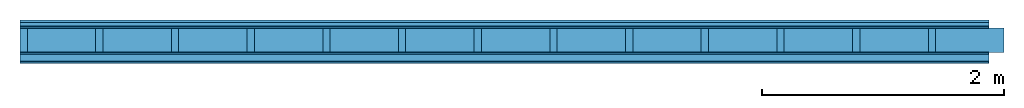
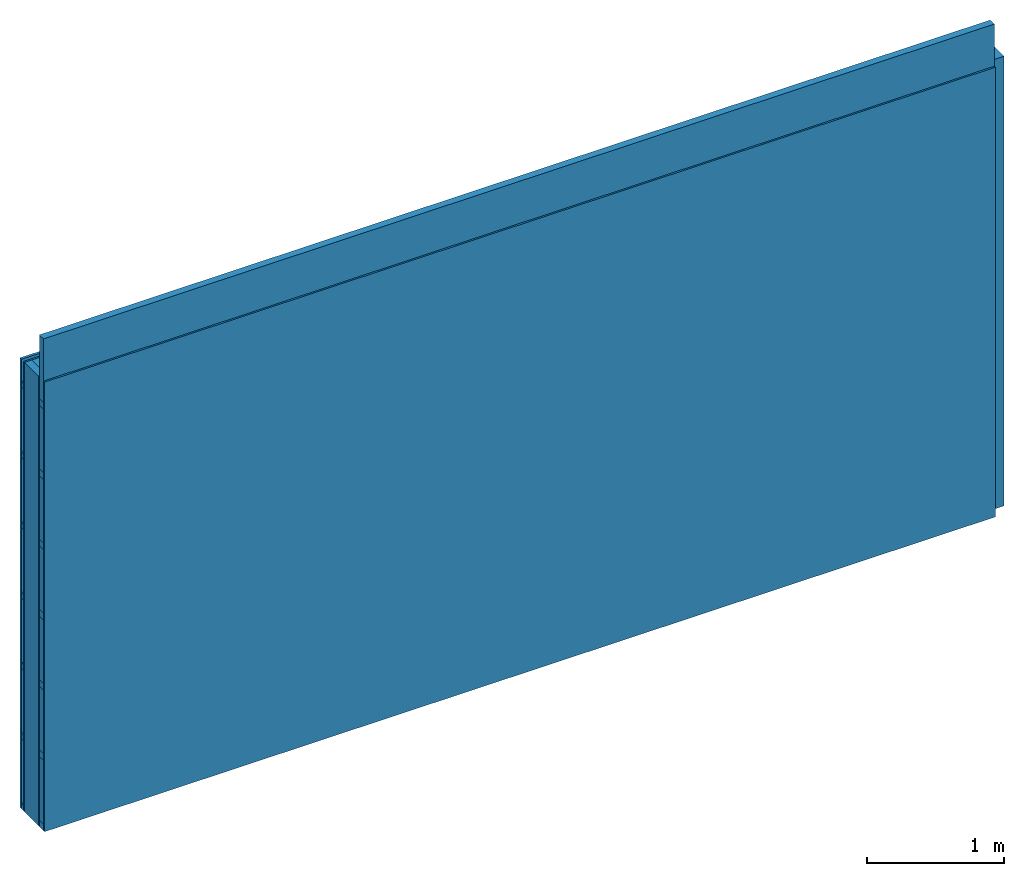
# One storey: 5 members, 4 plates, 1 element without a shape of its own.
"""IFC4 building model written with IfcOpenShell, lengths in metres."""

import ifcopenshell
import ifcopenshell.guid

model = None  # the IFC model being written
_history = None  # IfcOwnerHistory: only IFC2X3 demands one
_inside = {}  # id of a spatial element -> (the spatial element, [elements in it])
_under = {}  # id of a project, library or spatial element -> (it, [spatial elements below it])
_declared = {}  # id of a project -> (the project, [libraries it declares])
_typed = {}  # id of a type object -> (the type object, [elements of that type])
_made_of = {}  # id of a material, layer set ... -> (it, [elements and type objects made of it])


def new_model(schema):
    """Start an empty IFC model of exactly this schema.

    Asked for "IFC4X3", IfcOpenShell would pick the latest addendum, in which some entities
    have other attributes; the version numbers below select the first issue.
    IFC2X3 requires an IfcOwnerHistory on every rooted entity: one is made here for all.
    """
    global model, _history
    if schema == "IFC4X3":
        model = ifcopenshell.file(schema_version=(4, 3, 0, 0))
    else:
        model = ifcopenshell.file(schema=schema)
    _inside.clear()
    _under.clear()
    _declared.clear()
    _typed.clear()
    _made_of.clear()
    _history = None
    if model.schema == "IFC2X3":
        org = make("IfcOrganization", Name="unknown")
        user = make(
            "IfcPersonAndOrganization",
            ThePerson=make("IfcPerson", FamilyName="unknown"),
            TheOrganization=org,
        )
        app = make(
            "IfcApplication",
            ApplicationDeveloper=org,
            Version="unknown",
            ApplicationFullName="unknown",
            ApplicationIdentifier="unknown",
        )
        _history = make(
            "IfcOwnerHistory",
            OwningUser=user,
            OwningApplication=app,
            ChangeAction="ADDED",
            CreationDate=0,
        )
    return model


def make(cls, **values):
    """One entity of the class cls with the attributes given. An attribute that is None is left unset."""
    return model.create_entity(
        cls, **{name: value for name, value in values.items() if value is not None}
    )


def rooted(cls, **values):
    """An entity with a GlobalId (a new one), such as an element, a storey or a relation."""
    return make(cls, GlobalId=ifcopenshell.guid.new(), OwnerHistory=_history, **values)


def si_unit(unit_type, name, prefix=None):
    """IfcSIUnit, for example si_unit("LENGTHUNIT", "METRE", prefix="MILLI")."""
    return make("IfcSIUnit", UnitType=unit_type, Prefix=prefix, Name=name)


def derived_unit(unit_type, elements):
    """IfcDerivedUnit: a product of units, each with its exponent."""
    return make(
        "IfcDerivedUnit",
        Elements=[
            make("IfcDerivedUnitElement", Unit=unit, Exponent=power)
            for unit, power in elements
        ],
        UnitType=unit_type,
    )


def assignment(units):
    """IfcUnitAssignment: the units of a project."""
    return None if units is None else make("IfcUnitAssignment", Units=units)


def point(xyz):
    """IfcCartesianPoint."""
    return None if xyz is None else make("IfcCartesianPoint", Coordinates=xyz)


def direction(xyz):
    """IfcDirection."""
    return None if xyz is None else make("IfcDirection", DirectionRatios=xyz)


def frame(location, z_axis=None, x_axis=None):
    """IfcAxis2Placement3D, a coordinate frame: its origin and axes. An axis left out is left unset."""
    return make(
        "IfcAxis2Placement3D",
        Location=point(location),
        Axis=direction(z_axis),
        RefDirection=direction(x_axis),
    )


def frame_2d(location, x_axis=None):
    """IfcAxis2Placement2D, a coordinate frame in the plane: its origin and x axis."""
    return make(
        "IfcAxis2Placement2D", Location=point(location), RefDirection=direction(x_axis)
    )


def origin():
    """The frame at (0, 0, 0) with its axes left unset."""
    return frame((0.0, 0.0, 0.0))


def origin_with_axes():
    """The frame at (0, 0, 0) with the z axis (0, 0, 1) and the x axis (1, 0, 0) written out."""
    return frame((0.0, 0.0, 0.0), z_axis=(0.0, 0.0, 1.0), x_axis=(1.0, 0.0, 0.0))


def place(relative_to, where):
    """IfcLocalPlacement: puts the frame where relative to a parent placement (None: the world)."""
    return make(
        "IfcLocalPlacement", PlacementRelTo=relative_to, RelativePlacement=where
    )


def context(
    kind, dimensions, precision=None, world=None, true_north=None, identifier=None
):
    """IfcGeometricRepresentationContext, for example the 3D "Model" context."""
    return make(
        "IfcGeometricRepresentationContext",
        ContextIdentifier=identifier,
        ContextType=kind,
        CoordinateSpaceDimension=dimensions,
        Precision=precision,
        WorldCoordinateSystem=world,
        TrueNorth=true_north,
    )


def project(units=None, contexts=None):
    """IfcProject with its units and contexts."""
    return rooted(
        "IfcProject",
        Name="project",
        RepresentationContexts=contexts,
        UnitsInContext=assignment(units),
    )


def spatial(cls, under=None, at=None, **own):
    """A site, building, storey or space (cls), placed at a placement, below another one or the project."""
    s = rooted(cls, ObjectPlacement=at, **own)
    if under is not None:
        _under.setdefault(under.id(), (under, []))[1].append(s)
    return s


def profile(cls, at=None, kind="AREA", **sizes):
    """A parametric profile (cls). Its sizes go by their IFC names, for example OverallWidth=200.0."""
    return make(cls, ProfileType=kind, Position=at, **sizes)


def rectangle(**sizes):
    """IfcRectangleProfileDef."""
    return profile("IfcRectangleProfileDef", **sizes)


def extrude(swept, where, along, depth):
    """IfcExtrudedAreaSolid: the profile swept, set in the frame where, extruded along a direction by depth."""
    return make(
        "IfcExtrudedAreaSolid",
        SweptArea=swept,
        Position=where,
        ExtrudedDirection=direction(along),
        Depth=depth,
    )


def shape(context_of_items, identifier, shape_type, items):
    """IfcShapeRepresentation: the items that make up one representation, for example the "Body"."""
    return make(
        "IfcShapeRepresentation",
        ContextOfItems=context_of_items,
        RepresentationIdentifier=identifier,
        RepresentationType=shape_type,
        Items=items,
    )


def material(Name=None, Category=None):
    """IfcMaterial."""
    return make("IfcMaterial", Name=Name, Category=Category)


def layer(
    of_material, thickness, ventilated=None, Name=None, Category=None, Priority=None
):
    """IfcMaterialLayer: one layer of a wall or slab, of a material (None: an air gap)."""
    return make(
        "IfcMaterialLayer",
        Material=of_material,
        LayerThickness=thickness,
        IsVentilated=ventilated,
        Name=Name,
        Category=Category,
        Priority=Priority,
    )


def layer_set(layers, Name=None):
    """IfcMaterialLayerSet."""
    return make("IfcMaterialLayerSet", MaterialLayers=layers, LayerSetName=Name)


def made_of(thing, what):
    """Note that an element or type object is made of a material, layer set ...; save() writes the relation."""
    if what is not None:
        _made_of.setdefault(what.id(), (what, []))[1].append(thing)
    return thing


def type_object(cls, material=None, **own):
    """A type object (cls), such as IfcWallType, which elements share."""
    return made_of(rooted(cls, **own), material)


def element(
    cls,
    number,
    at=None,
    inside=None,
    cuts=None,
    type_object=None,
    material=None,
    context=None,
    identifier="Body",
    shape_type=None,
    held_by="IfcProductDefinitionShape",
    body=None,
    shapes=None,
    **own,
):
    """One element of the class cls, such as IfcWall. Its Tag is "e" and its number.

    at: its placement. inside: the storey or other place that contains it. cuts: it is an
    opening in that element (IfcRelVoidsElement). A single representation is given by context,
    identifier, shape_type and body (its items); several are given by shapes. held_by: the class
    of the entity that holds the representations. save() writes the other relations.
    """
    e = rooted(cls, Tag="e%d" % number, ObjectPlacement=at, **own)
    if body is not None:
        shapes = [shape(context, identifier, shape_type, body)]
    if shapes is not None:
        e.Representation = make(held_by, Representations=shapes)
    if inside is not None:
        _inside.setdefault(inside.id(), (inside, []))[1].append(e)
    if cuts is not None:
        rooted(
            "IfcRelVoidsElement", RelatingBuildingElement=cuts, RelatedOpeningElement=e
        )
    if type_object is not None:
        _typed.setdefault(type_object.id(), (type_object, []))[1].append(e)
    return made_of(e, material)


def aggregate(whole, parts):
    """IfcRelAggregates: a whole, such as a stair, and the parts it consists of."""
    return rooted("IfcRelAggregates", RelatingObject=whole, RelatedObjects=parts)


def save(model, path):
    """Write the relations noted so far, then the file.

    IfcRelAggregates (storeys below a building ...), IfcRelContainedInSpatialStructure (elements
    in a storey), IfcRelDefinesByType, IfcRelAssociatesMaterial and IfcRelDeclares: one each for
    every whole, place, type object, material and project.
    """
    for whole, parts in _under.values():
        aggregate(whole, parts)
    for where, things in _inside.values():
        rooted(
            "IfcRelContainedInSpatialStructure",
            RelatedElements=things,
            RelatingStructure=where,
        )
    for kind, things in _typed.values():
        rooted("IfcRelDefinesByType", RelatedObjects=things, RelatingType=kind)
    for what, things in _made_of.values():
        rooted("IfcRelAssociatesMaterial", RelatedObjects=things, RelatingMaterial=what)
    for by, libraries in _declared.values():
        rooted("IfcRelDeclares", RelatingContext=by, RelatedDefinitions=libraries)
    model.write(path)


model = new_model("IFC4")

# Units and contexts
plan_context = context("Plan", 3, precision=1e-05, world=origin(), true_north=direction((0.0, 1.0)))
model_context = context("Model", 3, precision=1e-05, world=origin(), true_north=direction((0.0, 1.0)))
ifc_project = project(units=[si_unit("LENGTHUNIT", "METRE"), derived_unit("SOUNDPRESSUREUNIT", [(si_unit("PRESSUREUNIT", "PASCAL", prefix="MICRO"), 0)]), si_unit("ENERGYUNIT", "JOULE", prefix="MEGA"), si_unit("MASSUNIT", "GRAM", prefix="KILO"), derived_unit("THERMALTRANSMITTANCEUNIT", [(si_unit("POWERUNIT", "WATT"), 1), (si_unit("AREAUNIT", "SQUARE_METRE"), -1), (si_unit("THERMODYNAMICTEMPERATUREUNIT", "KELVIN"), -1)]), derived_unit("AREADENSITYUNIT", [(si_unit("MASSUNIT", "GRAM", prefix="KILO"), 1), (si_unit("AREAUNIT", "SQUARE_METRE"), -1)]), derived_unit("USERDEFINED", [(si_unit("ENERGYUNIT", "JOULE", prefix="MEGA"), 1), (si_unit("AREAUNIT", "SQUARE_METRE"), -1)])], contexts=[plan_context, model_context])

# Site, building, storey
site = spatial("IfcSite", under=ifc_project)
building_placement = place(None, origin())
building = spatial("IfcBuilding", under=site, at=building_placement)
storey_placement = place(building_placement, origin())
storey = spatial("IfcBuildingStorey", under=building, at=storey_placement)

# Wall, members, plates
ifc_material_1 = material(Name="Wood cladding horizontal, closed")
ifc_layer_1 = layer(ifc_material_1, 0.022, Name="Cover 1st layer")
ifc_layer_2 = layer(None, 0.03, Name="Battens / profiles (ventilation)")
ifc_material_2 = material(Category="03.007")
ifc_layer_3 = layer(ifc_material_2, 0.015, Name="outside 1st layer")
ifc_material_3 = material(Name="of the art")
ifc_layer_4 = layer(ifc_material_3, 0.0, Name="Bond")
ifc_layer_5 = layer(None, 0.2, Name="Support")
ifc_layer_6 = layer(ifc_material_3, 0.0, Name="Bond")
ifc_layer_7 = layer(ifc_material_2, 0.015, Name="1st layer")
ifc_layer_8 = layer(None, 0.06, Name="Battens / profiles")
ifc_layer_9 = layer(ifc_material_2, 0.015, Name="Covering 1st layer")
ifc_material_4 = material(Name="Glued joints")
ifc_layer_10 = layer(ifc_material_4, 0.0, Name="Surface")
ifc_layer_set = layer_set([ifc_layer_1, ifc_layer_2, ifc_layer_3, ifc_layer_4, ifc_layer_5, ifc_layer_6, ifc_layer_7, ifc_layer_8, ifc_layer_9, ifc_layer_10])
wall_type = type_object("IfcWallType", Name="D0268", PredefinedType="NOTDEFINED", material=ifc_layer_set)
wall_placement = place(None, frame((0.0, 0.0, 0.0), z_axis=(0.0, -1.0, 0.0), x_axis=(1.0, 0.0, 0.0)))
wall = element("IfcWall", 1, at=wall_placement, inside=storey, type_object=wall_type, material=ifc_layer_set, Name="Wall #1")
ifc_material_5 = material()
member_1_placement = place(wall_placement, origin())
member_1 = element("IfcMember", 2, at=member_1_placement, material=ifc_material_5, Name="Battens / profiles (ventilation)", context=plan_context, shape_type="SweptSolid", body=[
    extrude(rectangle(XDim=0.05, YDim=0.03, at=frame_2d((0.025, 0.015), x_axis=(1.0, 0.0))), frame((0.0, 0.0, 0.022), z_axis=(1.0, 0.0, 0.0), x_axis=(0.0, 1.0, 0.0)), (0.0, 0.0, 1.0), 8.0),
    extrude(rectangle(XDim=0.05, YDim=0.03, at=frame_2d((0.025, 0.015), x_axis=(1.0, 0.0))), frame((0.0, 0.625, 0.022), z_axis=(1.0, 0.0, 0.0), x_axis=(0.0, 1.0, 0.0)), (0.0, 0.0, 1.0), 8.0),
    extrude(rectangle(XDim=0.05, YDim=0.03, at=frame_2d((0.025, 0.015), x_axis=(1.0, 0.0))), frame((0.0, 1.25, 0.022), z_axis=(1.0, 0.0, 0.0), x_axis=(0.0, 1.0, 0.0)), (0.0, 0.0, 1.0), 8.0),
    extrude(rectangle(XDim=0.05, YDim=0.03, at=frame_2d((0.025, 0.015), x_axis=(1.0, 0.0))), frame((0.0, 1.875, 0.022), z_axis=(1.0, 0.0, 0.0), x_axis=(0.0, 1.0, 0.0)), (0.0, 0.0, 1.0), 8.0),
    extrude(rectangle(XDim=0.05, YDim=0.03, at=frame_2d((0.025, 0.015), x_axis=(1.0, 0.0))), frame((0.0, 2.5, 0.022), z_axis=(1.0, 0.0, 0.0), x_axis=(0.0, 1.0, 0.0)), (0.0, 0.0, 1.0), 8.0),
    extrude(rectangle(XDim=0.05, YDim=0.03, at=frame_2d((0.025, 0.015), x_axis=(1.0, 0.0))), frame((0.0, 3.125, 0.022), z_axis=(1.0, 0.0, 0.0), x_axis=(0.0, 1.0, 0.0)), (0.0, 0.0, 1.0), 8.0),
    extrude(rectangle(XDim=0.05, YDim=0.03, at=frame_2d((0.025, 0.015), x_axis=(1.0, 0.0))), frame((0.0, 3.75, 0.022), z_axis=(1.0, 0.0, 0.0), x_axis=(0.0, 1.0, 0.0)), (0.0, 0.0, 1.0), 8.0),
])
ifc_material_6 = material()
member_2_placement = place(wall_placement, origin())
member_2 = element("IfcMember", 3, at=member_2_placement, material=ifc_material_6, Name="Support", context=plan_context, shape_type="SweptSolid", body=[
    extrude(rectangle(XDim=0.06, YDim=0.2, at=frame_2d((0.03, 0.1), x_axis=(1.0, 0.0))), frame((0.0, 4.0, 0.067), z_axis=(0.0, -1.0, 0.0), x_axis=(1.0, 0.0, 0.0)), (0.0, 0.0, 1.0), 4.0),
    extrude(rectangle(XDim=0.06, YDim=0.2, at=frame_2d((0.03, 0.1), x_axis=(1.0, 0.0))), frame((0.625, 4.0, 0.067), z_axis=(0.0, -1.0, 0.0), x_axis=(1.0, 0.0, 0.0)), (0.0, 0.0, 1.0), 4.0),
    extrude(rectangle(XDim=0.06, YDim=0.2, at=frame_2d((0.03, 0.1), x_axis=(1.0, 0.0))), frame((1.25, 4.0, 0.067), z_axis=(0.0, -1.0, 0.0), x_axis=(1.0, 0.0, 0.0)), (0.0, 0.0, 1.0), 4.0),
    extrude(rectangle(XDim=0.06, YDim=0.2, at=frame_2d((0.03, 0.1), x_axis=(1.0, 0.0))), frame((1.875, 4.0, 0.067), z_axis=(0.0, -1.0, 0.0), x_axis=(1.0, 0.0, 0.0)), (0.0, 0.0, 1.0), 4.0),
    extrude(rectangle(XDim=0.06, YDim=0.2, at=frame_2d((0.03, 0.1), x_axis=(1.0, 0.0))), frame((2.5, 4.0, 0.067), z_axis=(0.0, -1.0, 0.0), x_axis=(1.0, 0.0, 0.0)), (0.0, 0.0, 1.0), 4.0),
    extrude(rectangle(XDim=0.06, YDim=0.2, at=frame_2d((0.03, 0.1), x_axis=(1.0, 0.0))), frame((3.125, 4.0, 0.067), z_axis=(0.0, -1.0, 0.0), x_axis=(1.0, 0.0, 0.0)), (0.0, 0.0, 1.0), 4.0),
    extrude(rectangle(XDim=0.06, YDim=0.2, at=frame_2d((0.03, 0.1), x_axis=(1.0, 0.0))), frame((3.75, 4.0, 0.067), z_axis=(0.0, -1.0, 0.0), x_axis=(1.0, 0.0, 0.0)), (0.0, 0.0, 1.0), 4.0),
    extrude(rectangle(XDim=0.06, YDim=0.2, at=frame_2d((0.03, 0.1), x_axis=(1.0, 0.0))), frame((4.375, 4.0, 0.067), z_axis=(0.0, -1.0, 0.0), x_axis=(1.0, 0.0, 0.0)), (0.0, 0.0, 1.0), 4.0),
    extrude(rectangle(XDim=0.06, YDim=0.2, at=frame_2d((0.03, 0.1), x_axis=(1.0, 0.0))), frame((5.0, 4.0, 0.067), z_axis=(0.0, -1.0, 0.0), x_axis=(1.0, 0.0, 0.0)), (0.0, 0.0, 1.0), 4.0),
    extrude(rectangle(XDim=0.06, YDim=0.2, at=frame_2d((0.03, 0.1), x_axis=(1.0, 0.0))), frame((5.625, 4.0, 0.067), z_axis=(0.0, -1.0, 0.0), x_axis=(1.0, 0.0, 0.0)), (0.0, 0.0, 1.0), 4.0),
    extrude(rectangle(XDim=0.06, YDim=0.2, at=frame_2d((0.03, 0.1), x_axis=(1.0, 0.0))), frame((6.25, 4.0, 0.067), z_axis=(0.0, -1.0, 0.0), x_axis=(1.0, 0.0, 0.0)), (0.0, 0.0, 1.0), 4.0),
    extrude(rectangle(XDim=0.06, YDim=0.2, at=frame_2d((0.03, 0.1), x_axis=(1.0, 0.0))), frame((6.875, 4.0, 0.067), z_axis=(0.0, -1.0, 0.0), x_axis=(1.0, 0.0, 0.0)), (0.0, 0.0, 1.0), 4.0),
    extrude(rectangle(XDim=0.06, YDim=0.2, at=frame_2d((0.03, 0.1), x_axis=(1.0, 0.0))), frame((7.5, 4.0, 0.067), z_axis=(0.0, -1.0, 0.0), x_axis=(1.0, 0.0, 0.0)), (0.0, 0.0, 1.0), 4.0),
])
ifc_material_7 = material()
member_3_placement = place(wall_placement, origin())
member_3 = element("IfcMember", 4, at=member_3_placement, material=ifc_material_7, Name="Cavity", context=plan_context, shape_type="SweptSolid", body=[
    extrude(rectangle(XDim=0.565, YDim=0.2, at=frame_2d((0.2825, 0.1), x_axis=(1.0, 0.0))), frame((0.06, 4.0, 0.067), z_axis=(0.0, -1.0, 0.0), x_axis=(1.0, 0.0, 0.0)), (0.0, 0.0, 1.0), 4.0),
    extrude(rectangle(XDim=0.565, YDim=0.2, at=frame_2d((0.2825, 0.1), x_axis=(1.0, 0.0))), frame((0.685, 4.0, 0.067), z_axis=(0.0, -1.0, 0.0), x_axis=(1.0, 0.0, 0.0)), (0.0, 0.0, 1.0), 4.0),
    extrude(rectangle(XDim=0.565, YDim=0.2, at=frame_2d((0.2825, 0.1), x_axis=(1.0, 0.0))), frame((1.31, 4.0, 0.067), z_axis=(0.0, -1.0, 0.0), x_axis=(1.0, 0.0, 0.0)), (0.0, 0.0, 1.0), 4.0),
    extrude(rectangle(XDim=0.565, YDim=0.2, at=frame_2d((0.2825, 0.1), x_axis=(1.0, 0.0))), frame((1.935, 4.0, 0.067), z_axis=(0.0, -1.0, 0.0), x_axis=(1.0, 0.0, 0.0)), (0.0, 0.0, 1.0), 4.0),
    extrude(rectangle(XDim=0.565, YDim=0.2, at=frame_2d((0.2825, 0.1), x_axis=(1.0, 0.0))), frame((2.56, 4.0, 0.067), z_axis=(0.0, -1.0, 0.0), x_axis=(1.0, 0.0, 0.0)), (0.0, 0.0, 1.0), 4.0),
    extrude(rectangle(XDim=0.565, YDim=0.2, at=frame_2d((0.2825, 0.1), x_axis=(1.0, 0.0))), frame((3.185, 4.0, 0.067), z_axis=(0.0, -1.0, 0.0), x_axis=(1.0, 0.0, 0.0)), (0.0, 0.0, 1.0), 4.0),
    extrude(rectangle(XDim=0.565, YDim=0.2, at=frame_2d((0.2825, 0.1), x_axis=(1.0, 0.0))), frame((3.81, 4.0, 0.067), z_axis=(0.0, -1.0, 0.0), x_axis=(1.0, 0.0, 0.0)), (0.0, 0.0, 1.0), 4.0),
    extrude(rectangle(XDim=0.565, YDim=0.2, at=frame_2d((0.2825, 0.1), x_axis=(1.0, 0.0))), frame((4.435, 4.0, 0.067), z_axis=(0.0, -1.0, 0.0), x_axis=(1.0, 0.0, 0.0)), (0.0, 0.0, 1.0), 4.0),
    extrude(rectangle(XDim=0.565, YDim=0.2, at=frame_2d((0.2825, 0.1), x_axis=(1.0, 0.0))), frame((5.06, 4.0, 0.067), z_axis=(0.0, -1.0, 0.0), x_axis=(1.0, 0.0, 0.0)), (0.0, 0.0, 1.0), 4.0),
    extrude(rectangle(XDim=0.565, YDim=0.2, at=frame_2d((0.2825, 0.1), x_axis=(1.0, 0.0))), frame((5.685, 4.0, 0.067), z_axis=(0.0, -1.0, 0.0), x_axis=(1.0, 0.0, 0.0)), (0.0, 0.0, 1.0), 4.0),
    extrude(rectangle(XDim=0.565, YDim=0.2, at=frame_2d((0.2825, 0.1), x_axis=(1.0, 0.0))), frame((6.31, 4.0, 0.067), z_axis=(0.0, -1.0, 0.0), x_axis=(1.0, 0.0, 0.0)), (0.0, 0.0, 1.0), 4.0),
    extrude(rectangle(XDim=0.565, YDim=0.2, at=frame_2d((0.2825, 0.1), x_axis=(1.0, 0.0))), frame((6.935, 4.0, 0.067), z_axis=(0.0, -1.0, 0.0), x_axis=(1.0, 0.0, 0.0)), (0.0, 0.0, 1.0), 4.0),
    extrude(rectangle(XDim=0.565, YDim=0.2, at=frame_2d((0.2825, 0.1), x_axis=(1.0, 0.0))), frame((7.56, 4.0, 0.067), z_axis=(0.0, -1.0, 0.0), x_axis=(1.0, 0.0, 0.0)), (0.0, 0.0, 1.0), 4.0),
])
ifc_material_8 = material()
member_4_placement = place(wall_placement, origin())
member_4 = element("IfcMember", 5, at=member_4_placement, material=ifc_material_8, Name="Battens / profiles", context=plan_context, shape_type="SweptSolid", body=[
    extrude(rectangle(XDim=0.06, YDim=0.06, at=frame_2d((0.03, 0.03), x_axis=(1.0, 0.0))), frame((0.0, 0.0, 0.282), z_axis=(1.0, 0.0, 0.0), x_axis=(0.0, 1.0, 0.0)), (0.0, 0.0, 1.0), 8.0),
    extrude(rectangle(XDim=0.06, YDim=0.06, at=frame_2d((0.03, 0.03), x_axis=(1.0, 0.0))), frame((0.0, 0.625, 0.282), z_axis=(1.0, 0.0, 0.0), x_axis=(0.0, 1.0, 0.0)), (0.0, 0.0, 1.0), 8.0),
    extrude(rectangle(XDim=0.06, YDim=0.06, at=frame_2d((0.03, 0.03), x_axis=(1.0, 0.0))), frame((0.0, 1.25, 0.282), z_axis=(1.0, 0.0, 0.0), x_axis=(0.0, 1.0, 0.0)), (0.0, 0.0, 1.0), 8.0),
    extrude(rectangle(XDim=0.06, YDim=0.06, at=frame_2d((0.03, 0.03), x_axis=(1.0, 0.0))), frame((0.0, 1.875, 0.282), z_axis=(1.0, 0.0, 0.0), x_axis=(0.0, 1.0, 0.0)), (0.0, 0.0, 1.0), 8.0),
    extrude(rectangle(XDim=0.06, YDim=0.06, at=frame_2d((0.03, 0.03), x_axis=(1.0, 0.0))), frame((0.0, 2.5, 0.282), z_axis=(1.0, 0.0, 0.0), x_axis=(0.0, 1.0, 0.0)), (0.0, 0.0, 1.0), 8.0),
    extrude(rectangle(XDim=0.06, YDim=0.06, at=frame_2d((0.03, 0.03), x_axis=(1.0, 0.0))), frame((0.0, 3.125, 0.282), z_axis=(1.0, 0.0, 0.0), x_axis=(0.0, 1.0, 0.0)), (0.0, 0.0, 1.0), 8.0),
    extrude(rectangle(XDim=0.06, YDim=0.06, at=frame_2d((0.03, 0.03), x_axis=(1.0, 0.0))), frame((0.0, 3.75, 0.282), z_axis=(1.0, 0.0, 0.0), x_axis=(0.0, 1.0, 0.0)), (0.0, 0.0, 1.0), 8.0),
])
member_5_placement = place(wall_placement, origin())
member_5 = element("IfcMember", 6, at=member_5_placement, material=ifc_material_7, Name="Cavity", context=plan_context, shape_type="SweptSolid", body=[
    extrude(rectangle(XDim=0.565, YDim=0.06, at=frame_2d((0.2825, 0.03), x_axis=(1.0, 0.0))), frame((0.0, 0.06, 0.282), z_axis=(1.0, 0.0, 0.0), x_axis=(0.0, 1.0, 0.0)), (0.0, 0.0, 1.0), 8.0),
    extrude(rectangle(XDim=0.565, YDim=0.06, at=frame_2d((0.2825, 0.03), x_axis=(1.0, 0.0))), frame((0.0, 0.685, 0.282), z_axis=(1.0, 0.0, 0.0), x_axis=(0.0, 1.0, 0.0)), (0.0, 0.0, 1.0), 8.0),
    extrude(rectangle(XDim=0.565, YDim=0.06, at=frame_2d((0.2825, 0.03), x_axis=(1.0, 0.0))), frame((0.0, 1.31, 0.282), z_axis=(1.0, 0.0, 0.0), x_axis=(0.0, 1.0, 0.0)), (0.0, 0.0, 1.0), 8.0),
    extrude(rectangle(XDim=0.565, YDim=0.06, at=frame_2d((0.2825, 0.03), x_axis=(1.0, 0.0))), frame((0.0, 1.935, 0.282), z_axis=(1.0, 0.0, 0.0), x_axis=(0.0, 1.0, 0.0)), (0.0, 0.0, 1.0), 8.0),
    extrude(rectangle(XDim=0.565, YDim=0.06, at=frame_2d((0.2825, 0.03), x_axis=(1.0, 0.0))), frame((0.0, 2.56, 0.282), z_axis=(1.0, 0.0, 0.0), x_axis=(0.0, 1.0, 0.0)), (0.0, 0.0, 1.0), 8.0),
    extrude(rectangle(XDim=0.565, YDim=0.06, at=frame_2d((0.2825, 0.03), x_axis=(1.0, 0.0))), frame((0.0, 3.185, 0.282), z_axis=(1.0, 0.0, 0.0), x_axis=(0.0, 1.0, 0.0)), (0.0, 0.0, 1.0), 8.0),
    extrude(rectangle(XDim=0.565, YDim=0.06, at=frame_2d((0.2825, 0.03), x_axis=(1.0, 0.0))), frame((0.0, 3.81, 0.282), z_axis=(1.0, 0.0, 0.0), x_axis=(0.0, 1.0, 0.0)), (0.0, 0.0, 1.0), 8.0),
])
plate_1_placement = place(wall_placement, origin())
plate_1 = element("IfcPlate", 7, at=plate_1_placement, material=ifc_material_1, Name="Cover 1st layer", context=plan_context, shape_type="SweptSolid", body=[
    extrude(rectangle(XDim=8.0, YDim=4.0, at=frame_2d((4.0, 2.0), x_axis=(1.0, 0.0))), origin_with_axes(), (0.0, 0.0, 1.0), 0.022),
])
plate_2_placement = place(wall_placement, origin())
plate_2 = element("IfcPlate", 8, at=plate_2_placement, material=ifc_material_2, Name="outside 1st layer", context=plan_context, shape_type="SweptSolid", body=[
    extrude(rectangle(XDim=8.0, YDim=4.0, at=frame_2d((4.0, 2.0), x_axis=(1.0, 0.0))), frame((0.0, 0.0, 0.052), z_axis=(0.0, 0.0, 1.0), x_axis=(1.0, 0.0, 0.0)), (0.0, 0.0, 1.0), 0.015),
])
plate_3_placement = place(wall_placement, origin())
plate_3 = element("IfcPlate", 9, at=plate_3_placement, material=ifc_material_2, Name="1st layer", context=plan_context, shape_type="SweptSolid", body=[
    extrude(rectangle(XDim=8.0, YDim=4.0, at=frame_2d((4.0, 2.0), x_axis=(1.0, 0.0))), frame((0.0, 0.0, 0.267), z_axis=(0.0, 0.0, 1.0), x_axis=(1.0, 0.0, 0.0)), (0.0, 0.0, 1.0), 0.015),
])
plate_4_placement = place(wall_placement, origin())
plate_4 = element("IfcPlate", 10, at=plate_4_placement, material=ifc_material_2, Name="Covering 1st layer", context=plan_context, shape_type="SweptSolid", body=[
    extrude(rectangle(XDim=8.0, YDim=4.0, at=frame_2d((4.0, 2.0), x_axis=(1.0, 0.0))), frame((0.0, 0.0, 0.342), z_axis=(0.0, 0.0, 1.0), x_axis=(1.0, 0.0, 0.0)), (0.0, 0.0, 1.0), 0.015),
])
aggregate(wall, [plate_1, member_1, plate_2, member_2, member_3, plate_3, member_4, member_5, plate_4])

save(model, "model.ifc")
